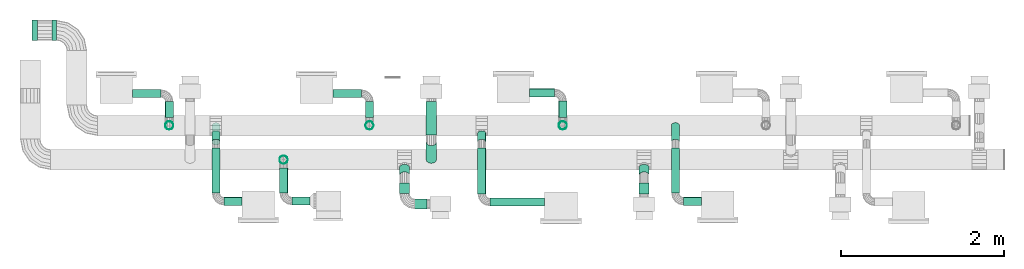
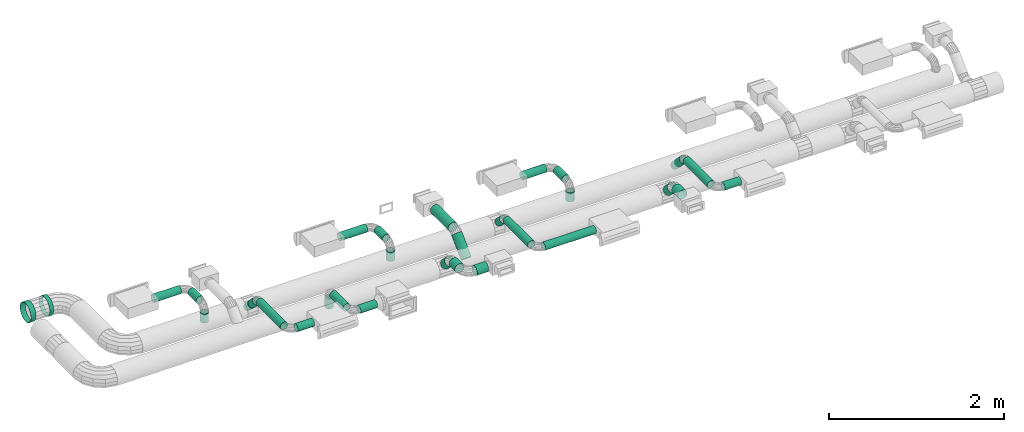
# One storey, part 2 of 11: 33 flow segments.
"""IFC2X3 building model written with IfcOpenShell, lengths in millimetres."""

from ifc_helpers import new_model, si_unit, derived_unit, frame, origin_with_axes, origin_2d_with_axis, place, context, project, spatial, hollow_circle, extrude, source, transform, mapped, type_object, element, save


model = new_model("IFC2X3")

# Units and contexts
context_of_model = context(None, 3, precision=1e-05, world=origin_with_axes())
ifc_project = project(units=[si_unit("LENGTHUNIT", "METRE", prefix="MILLI"), si_unit("AREAUNIT", "SQUARE_METRE"), si_unit("VOLUMEUNIT", "CUBIC_METRE"), si_unit("PLANEANGLEUNIT", "RADIAN"), si_unit("TIMEUNIT", "SECOND"), si_unit("POWERUNIT", "WATT"), si_unit("THERMODYNAMICTEMPERATUREUNIT", "DEGREE_CELSIUS"), derived_unit("VOLUMETRICFLOWRATEUNIT", [(si_unit("VOLUMEUNIT", "CUBIC_METRE"), 1), (si_unit("TIMEUNIT", "SECOND"), -1)])], contexts=[context_of_model])

# Site, building, storey
site_placement = place(None, origin_with_axes())
site = spatial("IfcSite", under=ifc_project, at=site_placement, CompositionType="ELEMENT")
building_placement = place(site_placement, origin_with_axes())
building = spatial("IfcBuilding", under=site, at=building_placement, CompositionType="ELEMENT")
storey_placement = place(building_placement, frame((0.0, 0.0, 3800.0), z_axis=(0.0, 0.0, 1.0), x_axis=(1.0, 0.0, 0.0)))
storey = spatial("IfcBuildingStorey", under=building, at=storey_placement, Name="First floor", CompositionType="ELEMENT")

# Flow segments
duct_segment_type_1 = type_object("IfcDuctSegmentType", PredefinedType="RIGIDSEGMENT")
shared_shape_1 = source(origin_with_axes(), context_of_model, "Body", "SweptSolid", [
    extrude(hollow_circle(Radius=63.0, WallThickness=2.0, at=origin_2d_with_axis()), frame((0.0, 0.0, 0.0), z_axis=(1.0, 0.0, 0.0), x_axis=(0.0, 1.0, 0.0)), (0.0, 0.0, 1.0), 306.0),
])
flow_segment_1_placement = place(storey_placement, frame((7863.52564, 4463.3661, 2566.12943), z_axis=(0.0, -0.707107, 0.707107), x_axis=(0.0, -0.707107, -0.707107)))
element("IfcFlowSegment", 1, at=flow_segment_1_placement, inside=storey, type_object=duct_segment_type_1, context=context_of_model, shape_type="MappedRepresentation", body=[
    mapped(shared_shape_1, transform((0.0, 0.0, 0.0), scale=1.0)),
])
duct_segment_type_2 = type_object("IfcDuctSegmentType", PredefinedType="RIGIDSEGMENT")
shared_shape_2 = source(origin_with_axes(), context_of_model, "Body", "SweptSolid", [
    extrude(hollow_circle(Radius=63.0, WallThickness=2.0, at=origin_2d_with_axis()), frame((0.0, 0.0, 0.0), z_axis=(1.0, 0.0, 0.0), x_axis=(0.0, 1.0, 0.0)), (0.0, 0.0, 1.0), 306.0),
])
flow_segment_2_placement = place(storey_placement, frame((7863.52564, 4957.70026, 2602.74108), z_axis=(0.0, 0.0, 1.0), x_axis=(0.0, -1.0, 0.0)))
element("IfcFlowSegment", 2, at=flow_segment_2_placement, inside=storey, type_object=duct_segment_type_2, context=context_of_model, shape_type="MappedRepresentation", body=[
    mapped(shared_shape_2, transform((0.0, 0.0, 0.0), scale=1.328126, scale2=1.0, scale3=1.0, uniform=False)),
])
duct_segment_type_3 = type_object("IfcDuctSegmentType", PredefinedType="RIGIDSEGMENT")
shared_shape_3 = source(origin_with_axes(), context_of_model, "Body", "SweptSolid", [
    extrude(hollow_circle(Radius=63.0, WallThickness=2.0, at=origin_2d_with_axis()), frame((0.0, 0.0, 0.0), z_axis=(1.0, 0.0, 0.0), x_axis=(0.0, 1.0, 0.0)), (0.0, 0.0, 1.0), 306.0),
])
flow_segment_3_placement = place(storey_placement, frame((4657.30247, 4665.04119, 2482.0), z_axis=(1.0, 0.0, 0.0), x_axis=(0.0, 0.0, -1.0)))
element("IfcFlowSegment", 3, at=flow_segment_3_placement, inside=storey, type_object=duct_segment_type_3, context=context_of_model, shape_type="MappedRepresentation", body=[
    mapped(shared_shape_3, transform((0.0, 0.0, 0.0), scale=0.425319, scale2=0.8, scale3=0.8, uniform=False)),
])
duct_segment_type_4 = type_object("IfcDuctSegmentType", PredefinedType="RIGIDSEGMENT")
shared_shape_4 = source(origin_with_axes(), context_of_model, "Body", "SweptSolid", [
    extrude(hollow_circle(Radius=63.0, WallThickness=2.0, at=origin_2d_with_axis()), frame((0.0, 0.0, 0.0), z_axis=(1.0, 0.0, 0.0), x_axis=(0.0, 1.0, 0.0)), (0.0, 0.0, 1.0), 306.0),
])
flow_segment_4_placement = place(storey_placement, frame((4657.30247, 4956.19157, 2582.0), z_axis=(0.0, 0.0, 1.0), x_axis=(0.0, -1.0, 0.0)))
element("IfcFlowSegment", 4, at=flow_segment_4_placement, inside=storey, type_object=duct_segment_type_4, context=context_of_model, shape_type="MappedRepresentation", body=[
    mapped(shared_shape_4, transform((0.0, 0.0, 0.0), scale=0.625383, scale2=0.8, scale3=0.8, uniform=False)),
])
duct_segment_type_5 = type_object("IfcDuctSegmentType", PredefinedType="RIGIDSEGMENT")
shared_shape_5 = source(origin_with_axes(), context_of_model, "Body", "SweptSolid", [
    extrude(hollow_circle(Radius=63.0, WallThickness=2.0, at=origin_2d_with_axis()), frame((0.0, 0.0, 0.0), z_axis=(1.0, 0.0, 0.0), x_axis=(0.0, 1.0, 0.0)), (0.0, 0.0, 1.0), 306.0),
])
flow_segment_5_placement = place(storey_placement, frame((4207.86052, 5056.19157, 2582.0), z_axis=(0.0, 0.0, 1.0), x_axis=(1.0, 0.0, 0.0)))
element("IfcFlowSegment", 5, at=flow_segment_5_placement, inside=storey, type_object=duct_segment_type_5, context=context_of_model, shape_type="MappedRepresentation", body=[
    mapped(shared_shape_5, transform((0.0, 0.0, 0.0), scale=1.143263, scale2=0.8, scale3=0.8, uniform=False)),
])
duct_segment_type_6 = type_object("IfcDuctSegmentType", PredefinedType="RIGIDSEGMENT")
shared_shape_6 = source(origin_with_axes(), context_of_model, "Body", "SweptSolid", [
    extrude(hollow_circle(Radius=63.0, WallThickness=2.0, at=origin_2d_with_axis()), frame((0.0, 0.0, 0.0), z_axis=(1.0, 0.0, 0.0), x_axis=(0.0, 1.0, 0.0)), (0.0, 0.0, 1.0), 306.0),
])
flow_segment_6_placement = place(storey_placement, frame((3044.78389, 5829.84592, 2350.0), z_axis=(0.0, 0.0, 1.0), x_axis=(-1.0, 0.0, 0.0)))
element("IfcFlowSegment", 6, at=flow_segment_6_placement, inside=storey, type_object=duct_segment_type_6, context=context_of_model, shape_type="MappedRepresentation", body=[
    mapped(shared_shape_6, transform((0.0, 0.0, 0.0), scale=0.223309, scale2=2.0, scale3=2.0, uniform=False)),
])
duct_segment_type_7 = type_object("IfcDuctSegmentType", PredefinedType="RIGIDSEGMENT")
shared_shape_7 = source(origin_with_axes(), context_of_model, "Body", "SweptSolid", [
    extrude(hollow_circle(Radius=63.0, WallThickness=2.0, at=origin_2d_with_axis()), frame((0.0, 0.0, 0.0), z_axis=(1.0, 0.0, 0.0), x_axis=(0.0, 1.0, 0.0)), (0.0, 0.0, 1.0), 306.0),
])
flow_segment_7_placement = place(storey_placement, frame((3276.65374, 5829.84592, 2350.0), z_axis=(0.0, 0.0, 1.0), x_axis=(-1.0, 0.0, 0.0)))
element("IfcFlowSegment", 7, at=flow_segment_7_placement, inside=storey, type_object=duct_segment_type_7, context=context_of_model, shape_type="MappedRepresentation", body=[
    mapped(shared_shape_7, transform((0.0, 0.0, 0.0), scale=0.169702, scale2=2.0, scale3=2.0, uniform=False)),
])
duct_segment_type_8 = type_object("IfcDuctSegmentType", PredefinedType="RIGIDSEGMENT")
shared_shape_8 = source(origin_with_axes(), context_of_model, "Body", "SweptSolid", [
    extrude(hollow_circle(Radius=63.0, WallThickness=2.0, at=origin_2d_with_axis()), frame((0.0, 0.0, 0.0), z_axis=(1.0, 0.0, 0.0), x_axis=(0.0, 1.0, 0.0)), (0.0, 0.0, 1.0), 306.0),
])
flow_segment_8_placement = place(storey_placement, frame((10466.34041, 4051.84832, 2545.38835), z_axis=(0.0, 0.707107, 0.707107), x_axis=(0.0, 0.707107, -0.707107)))
element("IfcFlowSegment", 8, at=flow_segment_8_placement, inside=storey, type_object=duct_segment_type_8, context=context_of_model, shape_type="MappedRepresentation", body=[
    mapped(shared_shape_8, transform((0.0, 0.0, 0.0), scale=0.43373, scale2=1.0, scale3=1.0, uniform=False)),
])
duct_segment_type_9 = type_object("IfcDuctSegmentType", PredefinedType="RIGIDSEGMENT")
shared_shape_9 = source(origin_with_axes(), context_of_model, "Body", "SweptSolid", [
    extrude(hollow_circle(Radius=63.0, WallThickness=2.0, at=origin_2d_with_axis()), frame((0.0, 0.0, 0.0), z_axis=(1.0, 0.0, 0.0), x_axis=(0.0, 1.0, 0.0)), (0.0, 0.0, 1.0), 306.0),
])
flow_segment_9_placement = place(storey_placement, frame((10466.34041, 3826.4086, 2582.0), z_axis=(0.0, 0.0, 1.0), x_axis=(0.0, 1.0, 0.0)))
element("IfcFlowSegment", 9, at=flow_segment_9_placement, inside=storey, type_object=duct_segment_type_9, context=context_of_model, shape_type="MappedRepresentation", body=[
    mapped(shared_shape_9, transform((0.0, 0.0, 0.0), scale=0.448389, scale2=1.0, scale3=1.0, uniform=False)),
])
shared_shape_10 = source(origin_with_axes(), context_of_model, "Body", "SweptSolid", [
    extrude(hollow_circle(Radius=63.0, WallThickness=2.0, at=origin_2d_with_axis()), frame((0.0, 0.0, 0.0), z_axis=(1.0, 0.0, 0.0), x_axis=(0.0, 1.0, 0.0)), (0.0, 0.0, 1.0), 306.0),
])
flow_segment_10_placement = place(storey_placement, frame((7535.55138, 4051.84832, 2545.38835), z_axis=(0.0, 0.707107, 0.707107), x_axis=(0.0, 0.707107, -0.707107)))
element("IfcFlowSegment", 10, at=flow_segment_10_placement, inside=storey, type_object=duct_segment_type_8, context=context_of_model, shape_type="MappedRepresentation", body=[
    mapped(shared_shape_10, transform((0.0, 0.0, 0.0), scale=0.43373, scale2=1.0, scale3=1.0, uniform=False)),
])
shared_shape_11 = source(origin_with_axes(), context_of_model, "Body", "SweptSolid", [
    extrude(hollow_circle(Radius=63.0, WallThickness=2.0, at=origin_2d_with_axis()), frame((0.0, 0.0, 0.0), z_axis=(1.0, 0.0, 0.0), x_axis=(0.0, 1.0, 0.0)), (0.0, 0.0, 1.0), 306.0),
])
flow_segment_11_placement = place(storey_placement, frame((7535.55138, 3830.33656, 2582.0), z_axis=(0.0, 0.0, 1.0), x_axis=(0.0, 1.0, 0.0)))
element("IfcFlowSegment", 11, at=flow_segment_11_placement, inside=storey, type_object=duct_segment_type_8, context=context_of_model, shape_type="MappedRepresentation", body=[
    mapped(shared_shape_11, transform((0.0, 0.0, 0.0), scale=0.435537, scale2=1.0, scale3=1.0, uniform=False)),
])
duct_segment_type_10 = type_object("IfcDuctSegmentType", PredefinedType="RIGIDSEGMENT")
shared_shape_12 = source(origin_with_axes(), context_of_model, "Body", "SweptSolid", [
    extrude(hollow_circle(Radius=63.0, WallThickness=2.0, at=origin_2d_with_axis()), frame((0.0, 0.0, 0.0), z_axis=(1.0, 0.0, 0.0), x_axis=(0.0, 1.0, 0.0)), (0.0, 0.0, 1.0), 306.0),
])
flow_segment_12_placement = place(storey_placement, frame((7810.31294, 3705.33656, 2582.0), z_axis=(0.0, 0.0, 1.0), x_axis=(-1.0, 0.0, 0.0)))
element("IfcFlowSegment", 12, at=flow_segment_12_placement, inside=storey, type_object=duct_segment_type_10, context=context_of_model, shape_type="MappedRepresentation", body=[
    mapped(shared_shape_12, transform((0.0, 0.0, 0.0), scale=0.489972, scale2=1.0, scale3=1.0, uniform=False)),
])
shared_shape_13 = source(origin_with_axes(), context_of_model, "Body", "SweptSolid", [
    extrude(hollow_circle(Radius=63.0, WallThickness=2.0, at=origin_2d_with_axis()), frame((0.0, 0.0, 0.0), z_axis=(1.0, 0.0, 0.0), x_axis=(0.0, 1.0, 0.0)), (0.0, 0.0, 1.0), 306.0),
])
flow_segment_13_placement = place(storey_placement, frame((9471.84245, 4665.58509, 2482.0), z_axis=(1.0, 0.0, 0.0), x_axis=(0.0, 0.0, -1.0)))
element("IfcFlowSegment", 13, at=flow_segment_13_placement, inside=storey, type_object=duct_segment_type_3, context=context_of_model, shape_type="MappedRepresentation", body=[
    mapped(shared_shape_13, transform((0.0, 0.0, 0.0), scale=0.425319, scale2=0.8, scale3=0.8, uniform=False)),
])
duct_segment_type_11 = type_object("IfcDuctSegmentType", PredefinedType="RIGIDSEGMENT")
shared_shape_14 = source(origin_with_axes(), context_of_model, "Body", "SweptSolid", [
    extrude(hollow_circle(Radius=63.0, WallThickness=2.0, at=origin_2d_with_axis()), frame((0.0, 0.0, 0.0), z_axis=(1.0, 0.0, 0.0), x_axis=(0.0, 1.0, 0.0)), (0.0, 0.0, 1.0), 306.0),
])
flow_segment_14_placement = place(storey_placement, frame((9471.84245, 4965.32653, 2582.0), z_axis=(0.0, 0.0, 1.0), x_axis=(0.0, -1.0, 0.0)))
element("IfcFlowSegment", 14, at=flow_segment_14_placement, inside=storey, type_object=duct_segment_type_11, context=context_of_model, shape_type="MappedRepresentation", body=[
    mapped(shared_shape_14, transform((0.0, 0.0, 0.0), scale=0.65349, scale2=0.8, scale3=0.8, uniform=False)),
])
duct_segment_type_12 = type_object("IfcDuctSegmentType", PredefinedType="RIGIDSEGMENT")
shared_shape_15 = source(origin_with_axes(), context_of_model, "Body", "SweptSolid", [
    extrude(hollow_circle(Radius=63.0, WallThickness=2.0, at=origin_2d_with_axis()), frame((0.0, 0.0, 0.0), z_axis=(1.0, 0.0, 0.0), x_axis=(0.0, 1.0, 0.0)), (0.0, 0.0, 1.0), 306.0),
])
flow_segment_15_placement = place(storey_placement, frame((9067.07418, 5065.32653, 2582.0), z_axis=(0.0, 0.0, 1.0), x_axis=(1.0, 0.0, 0.0)))
element("IfcFlowSegment", 15, at=flow_segment_15_placement, inside=storey, type_object=duct_segment_type_12, context=context_of_model, shape_type="MappedRepresentation", body=[
    mapped(shared_shape_15, transform((0.0, 0.0, 0.0), scale=0.997105, scale2=0.8, scale3=0.8, uniform=False)),
])
shared_shape_16 = source(origin_with_axes(), context_of_model, "Body", "SweptSolid", [
    extrude(hollow_circle(Radius=63.0, WallThickness=2.0, at=origin_2d_with_axis()), frame((0.0, 0.0, 0.0), z_axis=(1.0, 0.0, 0.0), x_axis=(0.0, 1.0, 0.0)), (0.0, 0.0, 1.0), 306.0),
])
flow_segment_16_placement = place(storey_placement, frame((6056.17496, 4245.83107, 2446.0), z_axis=(1.0, 0.0, 0.0), x_axis=(0.0, 0.0, -1.0)))
element("IfcFlowSegment", 16, at=flow_segment_16_placement, inside=storey, type_object=duct_segment_type_3, context=context_of_model, shape_type="MappedRepresentation", body=[
    mapped(shared_shape_16, transform((0.0, 0.0, 0.0), scale=0.425319, scale2=0.8, scale3=0.8, uniform=False)),
])
duct_segment_type_13 = type_object("IfcDuctSegmentType", PredefinedType="RIGIDSEGMENT")
shared_shape_17 = source(origin_with_axes(), context_of_model, "Body", "SweptSolid", [
    extrude(hollow_circle(Radius=63.0, WallThickness=2.0, at=origin_2d_with_axis()), frame((0.0, 0.0, 0.0), z_axis=(1.0, 0.0, 0.0), x_axis=(0.0, 1.0, 0.0)), (0.0, 0.0, 1.0), 306.0),
])
flow_segment_17_placement = place(storey_placement, frame((6056.17496, 3841.55397, 2546.0), z_axis=(0.0, 0.0, 1.0), x_axis=(0.0, 1.0, 0.0)))
element("IfcFlowSegment", 17, at=flow_segment_17_placement, inside=storey, type_object=duct_segment_type_13, context=context_of_model, shape_type="MappedRepresentation", body=[
    mapped(shared_shape_17, transform((0.0, 0.0, 0.0), scale=0.995498, scale2=0.8, scale3=0.8, uniform=False)),
])
duct_segment_type_14 = type_object("IfcDuctSegmentType", PredefinedType="RIGIDSEGMENT")
shared_shape_18 = source(origin_with_axes(), context_of_model, "Body", "SweptSolid", [
    extrude(hollow_circle(Radius=63.0, WallThickness=2.0, at=origin_2d_with_axis()), frame((0.0, 0.0, 0.0), z_axis=(1.0, 0.0, 0.0), x_axis=(0.0, 1.0, 0.0)), (0.0, 0.0, 1.0), 306.0),
])
flow_segment_18_placement = place(storey_placement, frame((6378.0958, 3741.55397, 2546.0), z_axis=(0.0, 0.0, 1.0), x_axis=(-1.0, 0.0, 0.0)))
element("IfcFlowSegment", 18, at=flow_segment_18_placement, inside=storey, type_object=duct_segment_type_14, context=context_of_model, shape_type="MappedRepresentation", body=[
    mapped(shared_shape_18, transform((0.0, 0.0, 0.0), scale=0.726054, scale2=0.8, scale3=0.8, uniform=False)),
])
shared_shape_19 = source(origin_with_axes(), context_of_model, "Body", "SweptSolid", [
    extrude(hollow_circle(Radius=63.0, WallThickness=2.0, at=origin_2d_with_axis()), frame((0.0, 0.0, 0.0), z_axis=(1.0, 0.0, 0.0), x_axis=(0.0, 1.0, 0.0)), (0.0, 0.0, 1.0), 306.0),
])
flow_segment_19_placement = place(storey_placement, frame((7107.82925, 4665.04119, 2482.43884), z_axis=(1.0, 0.0, 0.0), x_axis=(0.0, 0.0, -1.0)))
element("IfcFlowSegment", 19, at=flow_segment_19_placement, inside=storey, type_object=duct_segment_type_3, context=context_of_model, shape_type="MappedRepresentation", body=[
    mapped(shared_shape_19, transform((0.0, 0.0, 0.0), scale=0.425319, scale2=0.8, scale3=0.8, uniform=False)),
])
shared_shape_20 = source(origin_with_axes(), context_of_model, "Body", "SweptSolid", [
    extrude(hollow_circle(Radius=63.0, WallThickness=2.0, at=origin_2d_with_axis()), frame((0.0, 0.0, 0.0), z_axis=(1.0, 0.0, 0.0), x_axis=(0.0, 1.0, 0.0)), (0.0, 0.0, 1.0), 306.0),
])
flow_segment_20_placement = place(storey_placement, frame((7107.82925, 4956.19157, 2582.43884), z_axis=(0.0, 0.0, 1.0), x_axis=(0.0, -1.0, 0.0)))
element("IfcFlowSegment", 20, at=flow_segment_20_placement, inside=storey, type_object=duct_segment_type_4, context=context_of_model, shape_type="MappedRepresentation", body=[
    mapped(shared_shape_20, transform((0.0, 0.0, 0.0), scale=0.625383, scale2=0.8, scale3=0.8, uniform=False)),
])
shared_shape_21 = source(origin_with_axes(), context_of_model, "Body", "SweptSolid", [
    extrude(hollow_circle(Radius=63.0, WallThickness=2.0, at=origin_2d_with_axis()), frame((0.0, 0.0, 0.0), z_axis=(1.0, 0.0, 0.0), x_axis=(0.0, 1.0, 0.0)), (0.0, 0.0, 1.0), 306.0),
])
flow_segment_21_placement = place(storey_placement, frame((6658.3873, 5056.19157, 2582.43884), z_axis=(0.0, 0.0, 1.0), x_axis=(1.0, 0.0, 0.0)))
element("IfcFlowSegment", 21, at=flow_segment_21_placement, inside=storey, type_object=duct_segment_type_5, context=context_of_model, shape_type="MappedRepresentation", body=[
    mapped(shared_shape_21, transform((0.0, 0.0, 0.0), scale=1.143263, scale2=0.8, scale3=0.8, uniform=False)),
])
duct_segment_type_15 = type_object("IfcDuctSegmentType", PredefinedType="RIGIDSEGMENT")
shared_shape_22 = source(origin_with_axes(), context_of_model, "Body", "SweptSolid", [
    extrude(hollow_circle(Radius=63.0, WallThickness=2.0, at=origin_2d_with_axis()), frame((0.0, 0.0, 0.0), z_axis=(1.0, 0.0, 0.0), x_axis=(0.0, 1.0, 0.0)), (0.0, 0.0, 1.0), 306.0),
])
flow_segment_22_placement = place(storey_placement, frame((8479.69731, 4461.15678, 2552.71068), z_axis=(0.0, 0.707107, 0.707107), x_axis=(0.0, 0.707107, -0.707107)))
element("IfcFlowSegment", 22, at=flow_segment_22_placement, inside=storey, type_object=duct_segment_type_15, context=context_of_model, shape_type="MappedRepresentation", body=[
    mapped(shared_shape_22, transform((0.0, 0.0, 0.0), scale=0.479878, scale2=0.8, scale3=0.8, uniform=False)),
])
duct_segment_type_16 = type_object("IfcDuctSegmentType", PredefinedType="RIGIDSEGMENT")
shared_shape_23 = source(origin_with_axes(), context_of_model, "Body", "SweptSolid", [
    extrude(hollow_circle(Radius=63.0, WallThickness=2.0, at=origin_2d_with_axis()), frame((0.0, 0.0, 0.0), z_axis=(1.0, 0.0, 0.0), x_axis=(0.0, 1.0, 0.0)), (0.0, 0.0, 1.0), 306.0),
])
flow_segment_23_placement = place(storey_placement, frame((8479.69731, 3828.18389, 2582.0), z_axis=(0.0, 0.0, 1.0), x_axis=(0.0, 1.0, 0.0)))
element("IfcFlowSegment", 23, at=flow_segment_23_placement, inside=storey, type_object=duct_segment_type_16, context=context_of_model, shape_type="MappedRepresentation", body=[
    mapped(shared_shape_23, transform((0.0, 0.0, 0.0), scale=1.839543, scale2=0.8, scale3=0.8, uniform=False)),
])
duct_segment_type_17 = type_object("IfcDuctSegmentType", PredefinedType="RIGIDSEGMENT")
shared_shape_24 = source(origin_with_axes(), context_of_model, "Body", "SweptSolid", [
    extrude(hollow_circle(Radius=63.0, WallThickness=2.0, at=origin_2d_with_axis()), frame((0.0, 0.0, 0.0), z_axis=(1.0, 0.0, 0.0), x_axis=(0.0, 1.0, 0.0)), (0.0, 0.0, 1.0), 306.0),
])
flow_segment_24_placement = place(storey_placement, frame((9250.6008, 3728.18389, 2582.0), z_axis=(0.0, 0.0, 1.0), x_axis=(-1.0, 0.0, 0.0)))
element("IfcFlowSegment", 24, at=flow_segment_24_placement, inside=storey, type_object=duct_segment_type_17, context=context_of_model, shape_type="MappedRepresentation", body=[
    mapped(shared_shape_24, transform((0.0, 0.0, 0.0), scale=2.194983, scale2=0.8, scale3=0.8, uniform=False)),
])
shared_shape_25 = source(origin_with_axes(), context_of_model, "Body", "SweptSolid", [
    extrude(hollow_circle(Radius=63.0, WallThickness=2.0, at=origin_2d_with_axis()), frame((0.0, 0.0, 0.0), z_axis=(1.0, 0.0, 0.0), x_axis=(0.0, 1.0, 0.0)), (0.0, 0.0, 1.0), 306.0),
])
flow_segment_25_placement = place(storey_placement, frame((5228.1254, 4461.15678, 2552.71068), z_axis=(0.0, 0.707107, 0.707107), x_axis=(0.0, 0.707107, -0.707107)))
element("IfcFlowSegment", 25, at=flow_segment_25_placement, inside=storey, type_object=duct_segment_type_15, context=context_of_model, shape_type="MappedRepresentation", body=[
    mapped(shared_shape_25, transform((0.0, 0.0, 0.0), scale=0.479878, scale2=0.8, scale3=0.8, uniform=False)),
])
duct_segment_type_18 = type_object("IfcDuctSegmentType", PredefinedType="RIGIDSEGMENT")
shared_shape_26 = source(origin_with_axes(), context_of_model, "Body", "SweptSolid", [
    extrude(hollow_circle(Radius=63.0, WallThickness=2.0, at=origin_2d_with_axis()), frame((0.0, 0.0, 0.0), z_axis=(1.0, 0.0, 0.0), x_axis=(0.0, 1.0, 0.0)), (0.0, 0.0, 1.0), 306.0),
])
flow_segment_26_placement = place(storey_placement, frame((5228.1254, 3837.96868, 2582.0), z_axis=(0.0, 0.0, 1.0), x_axis=(0.0, 1.0, 0.0)))
element("IfcFlowSegment", 26, at=flow_segment_26_placement, inside=storey, type_object=duct_segment_type_18, context=context_of_model, shape_type="MappedRepresentation", body=[
    mapped(shared_shape_26, transform((0.0, 0.0, 0.0), scale=1.80753, scale2=0.8, scale3=0.8, uniform=False)),
])
duct_segment_type_19 = type_object("IfcDuctSegmentType", PredefinedType="RIGIDSEGMENT")
shared_shape_27 = source(origin_with_axes(), context_of_model, "Body", "SweptSolid", [
    extrude(hollow_circle(Radius=63.0, WallThickness=2.0, at=origin_2d_with_axis()), frame((0.0, 0.0, 0.0), z_axis=(1.0, 0.0, 0.0), x_axis=(0.0, 1.0, 0.0)), (0.0, 0.0, 1.0), 306.0),
])
flow_segment_27_placement = place(storey_placement, frame((5546.39829, 3737.96868, 2582.0), z_axis=(0.0, 0.0, 1.0), x_axis=(-1.0, 0.0, 0.0)))
element("IfcFlowSegment", 27, at=flow_segment_27_placement, inside=storey, type_object=duct_segment_type_19, context=context_of_model, shape_type="MappedRepresentation", body=[
    mapped(shared_shape_27, transform((0.0, 0.0, 0.0), scale=0.714119, scale2=0.8, scale3=0.8, uniform=False)),
])
duct_segment_type_20 = type_object("IfcDuctSegmentType", PredefinedType="RIGIDSEGMENT")
shared_shape_28 = source(origin_with_axes(), context_of_model, "Body", "SweptSolid", [
    extrude(hollow_circle(Radius=63.0, WallThickness=2.0, at=origin_2d_with_axis()), frame((0.0, 0.0, 0.0), z_axis=(1.0, 0.0, 0.0), x_axis=(0.0, 1.0, 0.0)), (0.0, 0.0, 1.0), 306.0),
])
flow_segment_28_placement = place(storey_placement, frame((5228.1254, 4461.15678, 2552.71068), z_axis=(0.0, 0.707107, 0.707107), x_axis=(0.0, 0.707107, -0.707107)))
element("IfcFlowSegment", 28, at=flow_segment_28_placement, inside=storey, type_object=duct_segment_type_20, context=context_of_model, shape_type="MappedRepresentation", body=[
    mapped(shared_shape_28, transform((0.0, 0.0, 0.0), scale=0.937913, scale2=0.8, scale3=0.8, uniform=False)),
])
shared_shape_29 = source(origin_with_axes(), context_of_model, "Body", "SweptSolid", [
    extrude(hollow_circle(Radius=63.0, WallThickness=2.0, at=origin_2d_with_axis()), frame((0.0, 0.0, 0.0), z_axis=(1.0, 0.0, 0.0), x_axis=(0.0, 1.0, 0.0)), (0.0, 0.0, 1.0), 306.0),
])
flow_segment_29_placement = place(storey_placement, frame((5228.1254, 3837.96868, 2582.0), z_axis=(0.0, 0.0, 1.0), x_axis=(0.0, 1.0, 0.0)))
element("IfcFlowSegment", 29, at=flow_segment_29_placement, inside=storey, type_object=duct_segment_type_18, context=context_of_model, shape_type="MappedRepresentation", body=[
    mapped(shared_shape_29, transform((0.0, 0.0, 0.0), scale=1.80753, scale2=0.8, scale3=0.8, uniform=False)),
])
shared_shape_30 = source(origin_with_axes(), context_of_model, "Body", "SweptSolid", [
    extrude(hollow_circle(Radius=63.0, WallThickness=2.0, at=origin_2d_with_axis()), frame((0.0, 0.0, 0.0), z_axis=(1.0, 0.0, 0.0), x_axis=(0.0, 1.0, 0.0)), (0.0, 0.0, 1.0), 306.0),
])
flow_segment_30_placement = place(storey_placement, frame((5546.39829, 3737.96868, 2582.0), z_axis=(0.0, 0.0, 1.0), x_axis=(-1.0, 0.0, 0.0)))
element("IfcFlowSegment", 30, at=flow_segment_30_placement, inside=storey, type_object=duct_segment_type_19, context=context_of_model, shape_type="MappedRepresentation", body=[
    mapped(shared_shape_30, transform((0.0, 0.0, 0.0), scale=0.714119, scale2=0.8, scale3=0.8, uniform=False)),
])
shared_shape_31 = source(origin_with_axes(), context_of_model, "Body", "SweptSolid", [
    extrude(hollow_circle(Radius=63.0, WallThickness=2.0, at=origin_2d_with_axis()), frame((0.0, 0.0, 0.0), z_axis=(1.0, 0.0, 0.0), x_axis=(0.0, 1.0, 0.0)), (0.0, 0.0, 1.0), 306.0),
])
flow_segment_31_placement = place(storey_placement, frame((10849.31334, 4461.15678, 2552.71068), z_axis=(0.0, 0.707107, 0.707107), x_axis=(0.0, 0.707107, -0.707107)))
element("IfcFlowSegment", 31, at=flow_segment_31_placement, inside=storey, type_object=duct_segment_type_20, context=context_of_model, shape_type="MappedRepresentation", body=[
    mapped(shared_shape_31, transform((0.0, 0.0, 0.0), scale=0.937913, scale2=0.8, scale3=0.8, uniform=False)),
])
shared_shape_32 = source(origin_with_axes(), context_of_model, "Body", "SweptSolid", [
    extrude(hollow_circle(Radius=63.0, WallThickness=2.0, at=origin_2d_with_axis()), frame((0.0, 0.0, 0.0), z_axis=(1.0, 0.0, 0.0), x_axis=(0.0, 1.0, 0.0)), (0.0, 0.0, 1.0), 306.0),
])
flow_segment_32_placement = place(storey_placement, frame((10849.31334, 3837.96868, 2582.0), z_axis=(0.0, 0.0, 1.0), x_axis=(0.0, 1.0, 0.0)))
element("IfcFlowSegment", 32, at=flow_segment_32_placement, inside=storey, type_object=duct_segment_type_18, context=context_of_model, shape_type="MappedRepresentation", body=[
    mapped(shared_shape_32, transform((0.0, 0.0, 0.0), scale=1.80753, scale2=0.8, scale3=0.8, uniform=False)),
])
shared_shape_33 = source(origin_with_axes(), context_of_model, "Body", "SweptSolid", [
    extrude(hollow_circle(Radius=63.0, WallThickness=2.0, at=origin_2d_with_axis()), frame((0.0, 0.0, 0.0), z_axis=(1.0, 0.0, 0.0), x_axis=(0.0, 1.0, 0.0)), (0.0, 0.0, 1.0), 306.0),
])
flow_segment_33_placement = place(storey_placement, frame((11167.58623, 3737.96868, 2582.0), z_axis=(0.0, 0.0, 1.0), x_axis=(-1.0, 0.0, 0.0)))
element("IfcFlowSegment", 33, at=flow_segment_33_placement, inside=storey, type_object=duct_segment_type_19, context=context_of_model, shape_type="MappedRepresentation", body=[
    mapped(shared_shape_33, transform((0.0, 0.0, 0.0), scale=0.714119, scale2=0.8, scale3=0.8, uniform=False)),
])

save(model, "model.ifc")
